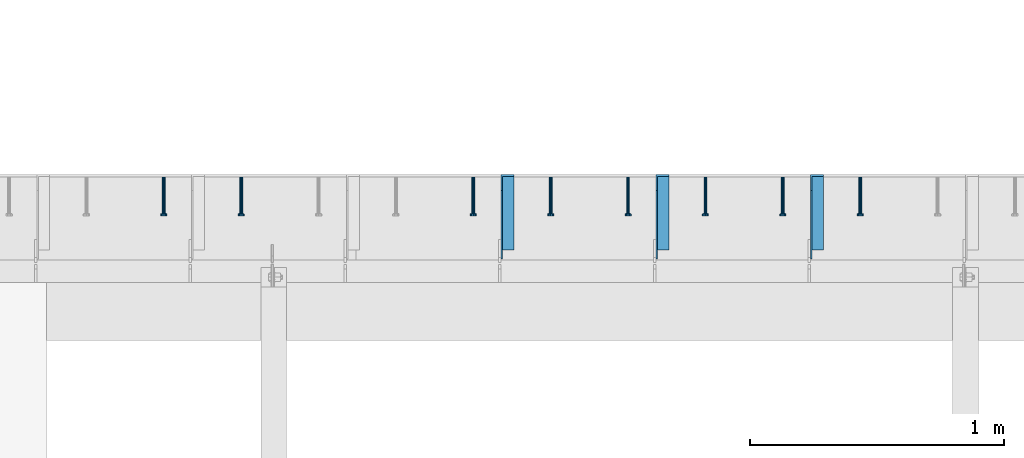
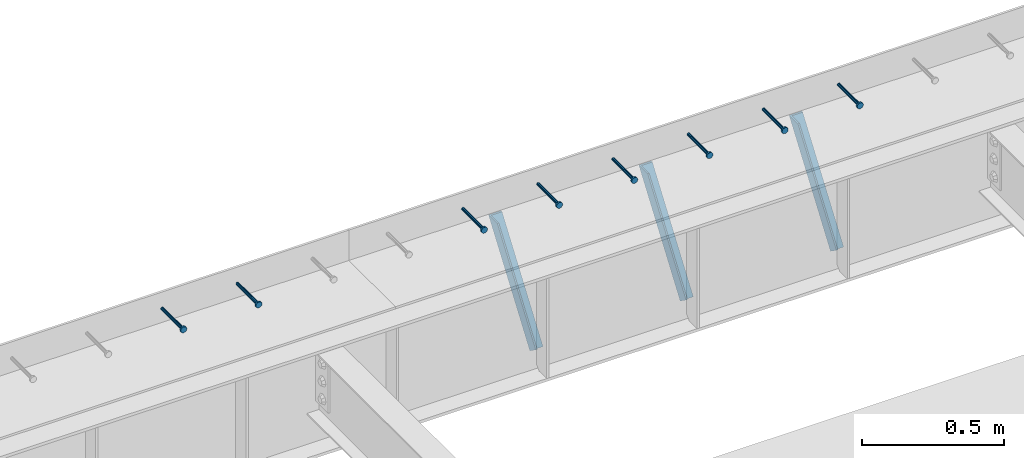
# One storey, part 1343 of 1763: 8 beams, 3 members, 9 elements without a shape of their own.
"""IFC2X3 building model written with IfcOpenShell, lengths in millimetres."""

from ifc_helpers import new_model, si_unit, frame, origin_with_axes, place, context, subcontext, project, spatial, faceted_brep, material, type_object, element, aggregate, save


model = new_model("IFC2X3")

# Units and contexts
model_context = context("Model", 3, precision=1e-05, world=origin_with_axes())
body_context = subcontext(model_context, "Body", "Model", "MODEL_VIEW")
ifc_project = project(units=[si_unit("LENGTHUNIT", "METRE", prefix="MILLI"), si_unit("AREAUNIT", "SQUARE_METRE"), si_unit("VOLUMEUNIT", "CUBIC_METRE"), si_unit("MASSUNIT", "GRAM", prefix="KILO"), si_unit("TIMEUNIT", "SECOND"), si_unit("PLANEANGLEUNIT", "RADIAN"), si_unit("SOLIDANGLEUNIT", "STERADIAN"), si_unit("THERMODYNAMICTEMPERATUREUNIT", "DEGREE_CELSIUS"), si_unit("LUMINOUSINTENSITYUNIT", "LUMEN")], contexts=[model_context])

# Site, building, storey
site_placement = place(None, origin_with_axes())
site = spatial("IfcSite", under=ifc_project, at=site_placement, CompositionType="ELEMENT")
building_placement = place(site_placement, origin_with_axes())
building = spatial("IfcBuilding", under=site, at=building_placement, Name="Undefined", CompositionType="ELEMENT")
storey_placement = place(building_placement, origin_with_axes())
storey = spatial("IfcBuildingStorey", under=building, at=storey_placement, Name="Undefined", CompositionType="ELEMENT", Elevation=0.0)

# Assembly, beam
assembly_1_placement = place(storey_placement, origin_with_axes())
assembly_1 = element("IfcElementAssembly", 1, at=assembly_1_placement, inside=storey, Name="HEADED STUD ANCHOR", AssemblyPlace="NOTDEFINED", PredefinedType="RIGID_FRAME")
ifc_material_1 = material(Name="STEEL/A108")
beam_type = type_object("IfcBeamType", PredefinedType="NOTDEFINED")
beam_1_placement = place(assembly_1_placement, frame((-67457.0747736983, 53984.5250183106, 5264.23140606069), z_axis=(0.0, 0.0, 1.0), x_axis=(0.0, -1.0, 0.0)))
beam_1 = element("IfcBeam", 2, at=beam_1_placement, type_object=beam_type, material=ifc_material_1, Name="HEADED STUD ANCHOR", context=body_context, shape_type="Brep", body=[
    faceted_brep([(0.0, -3.1800000667572, 5.5), (0.0, -5.5, 3.1800000667572), (141.732000000002, -5.5, 3.1800000667572), (141.732000000002, -3.1800000667572, 5.5), (0.0, -6.34999999999491, 1.45519152283669e-11), (141.732000000002, -6.34999990463257, 0.0), (0.0, -5.5, -3.1800000667572), (141.732000000002, -5.5, -3.1800000667572), (0.0, -3.1800000667572, -5.5), (141.732000000002, -3.1800000667572, -5.5), (0.0, 0.0, -6.34999990463257), (141.732000000002, 0.0, -6.34999990463257), (0.0, 3.1800000667572, -5.5), (141.732000000002, 3.1800000667572, -5.5), (0.0, 5.5, -3.1800000667572), (141.732000000002, 5.5, -3.1800000667572), (0.0, 6.34999999999491, -2.91038304567337e-11), (141.732000000002, 6.34999990463257, 0.0), (0.0, 5.5, 3.1800000667572), (141.732000000002, 5.5, 3.1800000667572), (0.0, 3.1800000667572, 5.5), (141.732000000002, 3.1800000667572, 5.5), (0.0, 0.0, 6.34999990463257), (141.732000000002, 0.0, 6.34999990463257), (144.780000000001, -10.9899997711182, 6.34999990463257), (144.780000000001, -6.34000015258789, 10.9899997711182), (144.780000000001, -12.6999998092651, 0.0), (144.780000000001, -10.9899997711182, -6.34999990463257), (144.780000000001, -6.34000015258789, -10.9899997711182), (144.780000000001, 0.0, -12.6899995803833), (144.780000000001, 6.34000015258789, -10.9899997711182), (144.780000000001, 10.9899997711182, -6.34999990463257), (144.780000000001, 12.6999998092651, 0.0), (144.780000000001, 10.9899997711182, 6.34999990463257), (144.780000000001, 6.34000015258789, 10.9899997711182), (144.780000000001, 0.0, 12.6899995803833), (152.400000000001, -10.9899997711182, 6.34999990463257), (152.400000000001, -6.34000015258789, 10.9899997711182), (152.400000000001, -12.6999998092651, 0.0), (152.400000000001, -10.9899997711182, -6.34999990463257), (152.400000000001, -6.34000015258789, -10.9899997711182), (152.400000000001, 0.0, -12.6899995803833), (152.400000000001, 6.34000015258789, -10.9899997711182), (152.400000000001, 10.9899997711182, -6.34999990463257), (152.400000000001, 12.6999998092651, 0.0), (152.400000000001, 10.9899997711182, 6.34999990463257), (152.400000000001, 6.34000015258789, 10.9899997711182), (152.400000000001, 0.0, 12.6899995803833)], [[[0, 1, 2, 3]], [[1, 4, 5, 2]], [[4, 6, 7, 5]], [[6, 8, 9, 7]], [[8, 10, 11, 9]], [[10, 12, 13, 11]], [[12, 14, 15, 13]], [[14, 16, 17, 15]], [[16, 18, 19, 17]], [[18, 20, 21, 19]], [[20, 22, 23, 21]], [[22, 0, 3, 23]], [[22, 20, 18, 16, 14, 12, 10, 8, 6, 4, 1, 0]], [[3, 2, 24, 25]], [[2, 5, 26, 24]], [[5, 7, 27, 26]], [[7, 9, 28, 27]], [[9, 11, 29, 28]], [[11, 13, 30, 29]], [[13, 15, 31, 30]], [[15, 17, 32, 31]], [[17, 19, 33, 32]], [[19, 21, 34, 33]], [[21, 23, 35, 34]], [[23, 3, 25, 35]], [[25, 24, 36, 37]], [[24, 26, 38, 36]], [[26, 27, 39, 38]], [[27, 28, 40, 39]], [[28, 29, 41, 40]], [[29, 30, 42, 41]], [[30, 31, 43, 42]], [[31, 32, 44, 43]], [[32, 33, 45, 44]], [[33, 34, 46, 45]], [[34, 35, 47, 46]], [[35, 25, 37, 47]], [[38, 39, 40, 41, 42, 43, 44, 45, 46, 47, 37, 36]]]),
])
aggregate(assembly_1, [beam_1])

assembly_2_placement = place(storey_placement, origin_with_axes())
assembly_2 = element("IfcElementAssembly", 3, at=assembly_2_placement, inside=storey, Name="HEADED STUD ANCHOR", AssemblyPlace="NOTDEFINED", PredefinedType="RIGID_FRAME")
beam_2_placement = place(assembly_2_placement, frame((-67761.8747736983, 53984.5250183106, 5264.23140606069), z_axis=(0.0, 0.0, 1.0), x_axis=(0.0, -1.0, 0.0)))
beam_2 = element("IfcBeam", 4, at=beam_2_placement, type_object=beam_type, material=ifc_material_1, Name="HEADED STUD ANCHOR", context=body_context, shape_type="Brep", body=[
    faceted_brep([(0.0, -3.1800000667572, 5.5), (0.0, -5.5, 3.1800000667572), (141.732000000002, -5.5, 3.1800000667572), (141.732000000002, -3.1800000667572, 5.5), (0.0, -6.34999999999491, 1.45519152283669e-11), (141.732000000002, -6.34999990463257, 0.0), (0.0, -5.5, -3.1800000667572), (141.732000000002, -5.5, -3.1800000667572), (0.0, -3.1800000667572, -5.5), (141.732000000002, -3.1800000667572, -5.5), (0.0, 0.0, -6.34999990463257), (141.732000000002, 0.0, -6.34999990463257), (0.0, 3.1800000667572, -5.5), (141.732000000002, 3.1800000667572, -5.5), (0.0, 5.5, -3.1800000667572), (141.732000000002, 5.5, -3.1800000667572), (0.0, 6.34999999999491, -2.91038304567337e-11), (141.732000000002, 6.34999990463257, 0.0), (0.0, 5.5, 3.1800000667572), (141.732000000002, 5.5, 3.1800000667572), (0.0, 3.1800000667572, 5.5), (141.732000000002, 3.1800000667572, 5.5), (0.0, 0.0, 6.34999990463257), (141.732000000002, 0.0, 6.34999990463257), (144.780000000001, -10.9899997711182, 6.34999990463257), (144.780000000001, -6.34000015258789, 10.9899997711182), (144.780000000001, -12.6999998092651, 0.0), (144.780000000001, -10.9899997711182, -6.34999990463257), (144.780000000001, -6.34000015258789, -10.9899997711182), (144.780000000001, 0.0, -12.6899995803833), (144.780000000001, 6.34000015258789, -10.9899997711182), (144.780000000001, 10.9899997711182, -6.34999990463257), (144.780000000001, 12.6999998092651, 0.0), (144.780000000001, 10.9899997711182, 6.34999990463257), (144.780000000001, 6.34000015258789, 10.9899997711182), (144.780000000001, 0.0, 12.6899995803833), (152.400000000001, -10.9899997711182, 6.34999990463257), (152.400000000001, -6.34000015258789, 10.9899997711182), (152.400000000001, -12.6999998092651, 0.0), (152.400000000001, -10.9899997711182, -6.34999990463257), (152.400000000001, -6.34000015258789, -10.9899997711182), (152.400000000001, 0.0, -12.6899995803833), (152.400000000001, 6.34000015258789, -10.9899997711182), (152.400000000001, 10.9899997711182, -6.34999990463257), (152.400000000001, 12.6999998092651, 0.0), (152.400000000001, 10.9899997711182, 6.34999990463257), (152.400000000001, 6.34000015258789, 10.9899997711182), (152.400000000001, 0.0, 12.6899995803833)], [[[0, 1, 2, 3]], [[1, 4, 5, 2]], [[4, 6, 7, 5]], [[6, 8, 9, 7]], [[8, 10, 11, 9]], [[10, 12, 13, 11]], [[12, 14, 15, 13]], [[14, 16, 17, 15]], [[16, 18, 19, 17]], [[18, 20, 21, 19]], [[20, 22, 23, 21]], [[22, 0, 3, 23]], [[22, 20, 18, 16, 14, 12, 10, 8, 6, 4, 1, 0]], [[3, 2, 24, 25]], [[2, 5, 26, 24]], [[5, 7, 27, 26]], [[7, 9, 28, 27]], [[9, 11, 29, 28]], [[11, 13, 30, 29]], [[13, 15, 31, 30]], [[15, 17, 32, 31]], [[17, 19, 33, 32]], [[19, 21, 34, 33]], [[21, 23, 35, 34]], [[23, 3, 25, 35]], [[25, 24, 36, 37]], [[24, 26, 38, 36]], [[26, 27, 39, 38]], [[27, 28, 40, 39]], [[28, 29, 41, 40]], [[29, 30, 42, 41]], [[30, 31, 43, 42]], [[31, 32, 44, 43]], [[32, 33, 45, 44]], [[33, 34, 46, 45]], [[34, 35, 47, 46]], [[35, 25, 37, 47]], [[38, 39, 40, 41, 42, 43, 44, 45, 46, 47, 37, 36]]]),
])
aggregate(assembly_2, [beam_2])

assembly_3_placement = place(storey_placement, origin_with_axes())
assembly_3 = element("IfcElementAssembly", 5, at=assembly_3_placement, inside=storey, Name="HEADED STUD ANCHOR", AssemblyPlace="NOTDEFINED", PredefinedType="RIGID_FRAME")
beam_3_placement = place(assembly_3_placement, frame((-68066.6747736984, 53984.5250183106, 5264.23140606069), z_axis=(0.0, 0.0, 1.0), x_axis=(0.0, -1.0, 0.0)))
beam_3 = element("IfcBeam", 6, at=beam_3_placement, type_object=beam_type, material=ifc_material_1, Name="HEADED STUD ANCHOR", context=body_context, shape_type="Brep", body=[
    faceted_brep([(0.0, -3.1800000667572, 5.5), (0.0, -5.5, 3.1800000667572), (141.732000000002, -5.5, 3.1800000667572), (141.732000000002, -3.1800000667572, 5.5), (0.0, -6.34999999999491, 1.45519152283669e-11), (141.732000000002, -6.34999990463257, 0.0), (0.0, -5.5, -3.1800000667572), (141.732000000002, -5.5, -3.1800000667572), (0.0, -3.1800000667572, -5.5), (141.732000000002, -3.1800000667572, -5.5), (0.0, 0.0, -6.34999990463257), (141.732000000002, 0.0, -6.34999990463257), (0.0, 3.1800000667572, -5.5), (141.732000000002, 3.1800000667572, -5.5), (0.0, 5.5, -3.1800000667572), (141.732000000002, 5.5, -3.1800000667572), (0.0, 6.34999999999491, -2.91038304567337e-11), (141.732000000002, 6.34999990463257, 0.0), (0.0, 5.5, 3.1800000667572), (141.732000000002, 5.5, 3.1800000667572), (0.0, 3.1800000667572, 5.5), (141.732000000002, 3.1800000667572, 5.5), (0.0, 0.0, 6.34999990463257), (141.732000000002, 0.0, 6.34999990463257), (144.780000000001, -10.9899997711182, 6.34999990463257), (144.780000000001, -6.34000015258789, 10.9899997711182), (144.780000000001, -12.6999998092651, 0.0), (144.780000000001, -10.9899997711182, -6.34999990463257), (144.780000000001, -6.34000015258789, -10.9899997711182), (144.780000000001, 0.0, -12.6899995803833), (144.780000000001, 6.34000015258789, -10.9899997711182), (144.780000000001, 10.9899997711182, -6.34999990463257), (144.780000000001, 12.6999998092651, 0.0), (144.780000000001, 10.9899997711182, 6.34999990463257), (144.780000000001, 6.34000015258789, 10.9899997711182), (144.780000000001, 0.0, 12.6899995803833), (152.400000000001, -10.9899997711182, 6.34999990463257), (152.400000000001, -6.34000015258789, 10.9899997711182), (152.400000000001, -12.6999998092651, 0.0), (152.400000000001, -10.9899997711182, -6.34999990463257), (152.400000000001, -6.34000015258789, -10.9899997711182), (152.400000000001, 0.0, -12.6899995803833), (152.400000000001, 6.34000015258789, -10.9899997711182), (152.400000000001, 10.9899997711182, -6.34999990463257), (152.400000000001, 12.6999998092651, 0.0), (152.400000000001, 10.9899997711182, 6.34999990463257), (152.400000000001, 6.34000015258789, 10.9899997711182), (152.400000000001, 0.0, 12.6899995803833)], [[[0, 1, 2, 3]], [[1, 4, 5, 2]], [[4, 6, 7, 5]], [[6, 8, 9, 7]], [[8, 10, 11, 9]], [[10, 12, 13, 11]], [[12, 14, 15, 13]], [[14, 16, 17, 15]], [[16, 18, 19, 17]], [[18, 20, 21, 19]], [[20, 22, 23, 21]], [[22, 0, 3, 23]], [[22, 20, 18, 16, 14, 12, 10, 8, 6, 4, 1, 0]], [[3, 2, 24, 25]], [[2, 5, 26, 24]], [[5, 7, 27, 26]], [[7, 9, 28, 27]], [[9, 11, 29, 28]], [[11, 13, 30, 29]], [[13, 15, 31, 30]], [[15, 17, 32, 31]], [[17, 19, 33, 32]], [[19, 21, 34, 33]], [[21, 23, 35, 34]], [[23, 3, 25, 35]], [[25, 24, 36, 37]], [[24, 26, 38, 36]], [[26, 27, 39, 38]], [[27, 28, 40, 39]], [[28, 29, 41, 40]], [[29, 30, 42, 41]], [[30, 31, 43, 42]], [[31, 32, 44, 43]], [[32, 33, 45, 44]], [[33, 34, 46, 45]], [[34, 35, 47, 46]], [[35, 25, 37, 47]], [[38, 39, 40, 41, 42, 43, 44, 45, 46, 47, 37, 36]]]),
])
aggregate(assembly_3, [beam_3])

assembly_4_placement = place(storey_placement, origin_with_axes())
assembly_4 = element("IfcElementAssembly", 7, at=assembly_4_placement, inside=storey, Name="HEADED STUD ANCHOR", AssemblyPlace="NOTDEFINED", PredefinedType="RIGID_FRAME")
beam_4_placement = place(assembly_4_placement, frame((-68371.4747736984, 53984.5250183106, 5264.23140606069), z_axis=(0.0, 0.0, 1.0), x_axis=(0.0, -1.0, 0.0)))
beam_4 = element("IfcBeam", 8, at=beam_4_placement, type_object=beam_type, material=ifc_material_1, Name="HEADED STUD ANCHOR", context=body_context, shape_type="Brep", body=[
    faceted_brep([(0.0, -3.1800000667572, 5.5), (0.0, -5.5, 3.1800000667572), (141.732000000002, -5.5, 3.1800000667572), (141.732000000002, -3.1800000667572, 5.5), (0.0, -6.34999999999491, 1.45519152283669e-11), (141.732000000002, -6.34999990463257, 0.0), (0.0, -5.5, -3.1800000667572), (141.732000000002, -5.5, -3.1800000667572), (0.0, -3.1800000667572, -5.5), (141.732000000002, -3.1800000667572, -5.5), (0.0, 0.0, -6.34999990463257), (141.732000000002, 0.0, -6.34999990463257), (0.0, 3.1800000667572, -5.5), (141.732000000002, 3.1800000667572, -5.5), (0.0, 5.5, -3.1800000667572), (141.732000000002, 5.5, -3.1800000667572), (0.0, 6.34999999999491, -2.91038304567337e-11), (141.732000000002, 6.34999990463257, 0.0), (0.0, 5.5, 3.1800000667572), (141.732000000002, 5.5, 3.1800000667572), (0.0, 3.1800000667572, 5.5), (141.732000000002, 3.1800000667572, 5.5), (0.0, 0.0, 6.34999990463257), (141.732000000002, 0.0, 6.34999990463257), (144.780000000001, -10.9899997711182, 6.34999990463257), (144.780000000001, -6.34000015258789, 10.9899997711182), (144.780000000001, -12.6999998092651, 0.0), (144.780000000001, -10.9899997711182, -6.34999990463257), (144.780000000001, -6.34000015258789, -10.9899997711182), (144.780000000001, 0.0, -12.6899995803833), (144.780000000001, 6.34000015258789, -10.9899997711182), (144.780000000001, 10.9899997711182, -6.34999990463257), (144.780000000001, 12.6999998092651, 0.0), (144.780000000001, 10.9899997711182, 6.34999990463257), (144.780000000001, 6.34000015258789, 10.9899997711182), (144.780000000001, 0.0, 12.6899995803833), (152.400000000001, -10.9899997711182, 6.34999990463257), (152.400000000001, -6.34000015258789, 10.9899997711182), (152.400000000001, -12.6999998092651, 0.0), (152.400000000001, -10.9899997711182, -6.34999990463257), (152.400000000001, -6.34000015258789, -10.9899997711182), (152.400000000001, 0.0, -12.6899995803833), (152.400000000001, 6.34000015258789, -10.9899997711182), (152.400000000001, 10.9899997711182, -6.34999990463257), (152.400000000001, 12.6999998092651, 0.0), (152.400000000001, 10.9899997711182, 6.34999990463257), (152.400000000001, 6.34000015258789, 10.9899997711182), (152.400000000001, 0.0, 12.6899995803833)], [[[0, 1, 2, 3]], [[1, 4, 5, 2]], [[4, 6, 7, 5]], [[6, 8, 9, 7]], [[8, 10, 11, 9]], [[10, 12, 13, 11]], [[12, 14, 15, 13]], [[14, 16, 17, 15]], [[16, 18, 19, 17]], [[18, 20, 21, 19]], [[20, 22, 23, 21]], [[22, 0, 3, 23]], [[22, 20, 18, 16, 14, 12, 10, 8, 6, 4, 1, 0]], [[3, 2, 24, 25]], [[2, 5, 26, 24]], [[5, 7, 27, 26]], [[7, 9, 28, 27]], [[9, 11, 29, 28]], [[11, 13, 30, 29]], [[13, 15, 31, 30]], [[15, 17, 32, 31]], [[17, 19, 33, 32]], [[19, 21, 34, 33]], [[21, 23, 35, 34]], [[23, 3, 25, 35]], [[25, 24, 36, 37]], [[24, 26, 38, 36]], [[26, 27, 39, 38]], [[27, 28, 40, 39]], [[28, 29, 41, 40]], [[29, 30, 42, 41]], [[30, 31, 43, 42]], [[31, 32, 44, 43]], [[32, 33, 45, 44]], [[33, 34, 46, 45]], [[34, 35, 47, 46]], [[35, 25, 37, 47]], [[38, 39, 40, 41, 42, 43, 44, 45, 46, 47, 37, 36]]]),
])
aggregate(assembly_4, [beam_4])

assembly_5_placement = place(storey_placement, origin_with_axes())
assembly_5 = element("IfcElementAssembly", 9, at=assembly_5_placement, inside=storey, Name="HEADED STUD ANCHOR", AssemblyPlace="NOTDEFINED", PredefinedType="RIGID_FRAME")
beam_5_placement = place(assembly_5_placement, frame((-68676.2747736983, 53984.5250183106, 5264.23140606069), z_axis=(0.0, 0.0, 1.0), x_axis=(0.0, -1.0, 0.0)))
beam_5 = element("IfcBeam", 10, at=beam_5_placement, type_object=beam_type, material=ifc_material_1, Name="HEADED STUD ANCHOR", context=body_context, shape_type="Brep", body=[
    faceted_brep([(0.0, -3.1800000667572, 5.5), (0.0, -5.5, 3.1800000667572), (141.732000000002, -5.5, 3.1800000667572), (141.732000000002, -3.1800000667572, 5.5), (0.0, -6.34999999999491, 1.45519152283669e-11), (141.732000000002, -6.34999990463257, 0.0), (0.0, -5.5, -3.1800000667572), (141.732000000002, -5.5, -3.1800000667572), (0.0, -3.1800000667572, -5.5), (141.732000000002, -3.1800000667572, -5.5), (0.0, 0.0, -6.34999990463257), (141.732000000002, 0.0, -6.34999990463257), (0.0, 3.1800000667572, -5.5), (141.732000000002, 3.1800000667572, -5.5), (0.0, 5.5, -3.1800000667572), (141.732000000002, 5.5, -3.1800000667572), (0.0, 6.34999999999491, -2.91038304567337e-11), (141.732000000002, 6.34999990463257, 0.0), (0.0, 5.5, 3.1800000667572), (141.732000000002, 5.5, 3.1800000667572), (0.0, 3.1800000667572, 5.5), (141.732000000002, 3.1800000667572, 5.5), (0.0, 0.0, 6.34999990463257), (141.732000000002, 0.0, 6.34999990463257), (144.780000000001, -10.9899997711182, 6.34999990463257), (144.780000000001, -6.34000015258789, 10.9899997711182), (144.780000000001, -12.6999998092651, 0.0), (144.780000000001, -10.9899997711182, -6.34999990463257), (144.780000000001, -6.34000015258789, -10.9899997711182), (144.780000000001, 0.0, -12.6899995803833), (144.780000000001, 6.34000015258789, -10.9899997711182), (144.780000000001, 10.9899997711182, -6.34999990463257), (144.780000000001, 12.6999998092651, 0.0), (144.780000000001, 10.9899997711182, 6.34999990463257), (144.780000000001, 6.34000015258789, 10.9899997711182), (144.780000000001, 0.0, 12.6899995803833), (152.400000000001, -10.9899997711182, 6.34999990463257), (152.400000000001, -6.34000015258789, 10.9899997711182), (152.400000000001, -12.6999998092651, 0.0), (152.400000000001, -10.9899997711182, -6.34999990463257), (152.400000000001, -6.34000015258789, -10.9899997711182), (152.400000000001, 0.0, -12.6899995803833), (152.400000000001, 6.34000015258789, -10.9899997711182), (152.400000000001, 10.9899997711182, -6.34999990463257), (152.400000000001, 12.6999998092651, 0.0), (152.400000000001, 10.9899997711182, 6.34999990463257), (152.400000000001, 6.34000015258789, 10.9899997711182), (152.400000000001, 0.0, 12.6899995803833)], [[[0, 1, 2, 3]], [[1, 4, 5, 2]], [[4, 6, 7, 5]], [[6, 8, 9, 7]], [[8, 10, 11, 9]], [[10, 12, 13, 11]], [[12, 14, 15, 13]], [[14, 16, 17, 15]], [[16, 18, 19, 17]], [[18, 20, 21, 19]], [[20, 22, 23, 21]], [[22, 0, 3, 23]], [[22, 20, 18, 16, 14, 12, 10, 8, 6, 4, 1, 0]], [[3, 2, 24, 25]], [[2, 5, 26, 24]], [[5, 7, 27, 26]], [[7, 9, 28, 27]], [[9, 11, 29, 28]], [[11, 13, 30, 29]], [[13, 15, 31, 30]], [[15, 17, 32, 31]], [[17, 19, 33, 32]], [[19, 21, 34, 33]], [[21, 23, 35, 34]], [[23, 3, 25, 35]], [[25, 24, 36, 37]], [[24, 26, 38, 36]], [[26, 27, 39, 38]], [[27, 28, 40, 39]], [[28, 29, 41, 40]], [[29, 30, 42, 41]], [[30, 31, 43, 42]], [[31, 32, 44, 43]], [[32, 33, 45, 44]], [[33, 34, 46, 45]], [[34, 35, 47, 46]], [[35, 25, 37, 47]], [[38, 39, 40, 41, 42, 43, 44, 45, 46, 47, 37, 36]]]),
])
aggregate(assembly_5, [beam_5])

assembly_6_placement = place(storey_placement, origin_with_axes())
assembly_6 = element("IfcElementAssembly", 11, at=assembly_6_placement, inside=storey, Name="HEADED STUD ANCHOR", AssemblyPlace="NOTDEFINED", PredefinedType="RIGID_FRAME")
beam_6_placement = place(assembly_6_placement, frame((-68981.0747736983, 53984.5250183106, 5264.23140606069), z_axis=(0.0, 0.0, 1.0), x_axis=(0.0, -1.0, 0.0)))
beam_6 = element("IfcBeam", 12, at=beam_6_placement, type_object=beam_type, material=ifc_material_1, Name="HEADED STUD ANCHOR", context=body_context, shape_type="Brep", body=[
    faceted_brep([(0.0, -3.1800000667572, 5.5), (0.0, -5.5, 3.1800000667572), (141.732000000002, -5.5, 3.1800000667572), (141.732000000002, -3.1800000667572, 5.5), (0.0, -6.34999999999491, 1.45519152283669e-11), (141.732000000002, -6.34999990463257, 0.0), (0.0, -5.5, -3.1800000667572), (141.732000000002, -5.5, -3.1800000667572), (0.0, -3.1800000667572, -5.5), (141.732000000002, -3.1800000667572, -5.5), (0.0, 0.0, -6.34999990463257), (141.732000000002, 0.0, -6.34999990463257), (0.0, 3.1800000667572, -5.5), (141.732000000002, 3.1800000667572, -5.5), (0.0, 5.5, -3.1800000667572), (141.732000000002, 5.5, -3.1800000667572), (0.0, 6.34999999999491, -2.91038304567337e-11), (141.732000000002, 6.34999990463257, 0.0), (0.0, 5.5, 3.1800000667572), (141.732000000002, 5.5, 3.1800000667572), (0.0, 3.1800000667572, 5.5), (141.732000000002, 3.1800000667572, 5.5), (0.0, 0.0, 6.34999990463257), (141.732000000002, 0.0, 6.34999990463257), (144.780000000001, -10.9899997711182, 6.34999990463257), (144.780000000001, -6.34000015258789, 10.9899997711182), (144.780000000001, -12.6999998092651, 0.0), (144.780000000001, -10.9899997711182, -6.34999990463257), (144.780000000001, -6.34000015258789, -10.9899997711182), (144.780000000001, 0.0, -12.6899995803833), (144.780000000001, 6.34000015258789, -10.9899997711182), (144.780000000001, 10.9899997711182, -6.34999990463257), (144.780000000001, 12.6999998092651, 0.0), (144.780000000001, 10.9899997711182, 6.34999990463257), (144.780000000001, 6.34000015258789, 10.9899997711182), (144.780000000001, 0.0, 12.6899995803833), (152.400000000001, -10.9899997711182, 6.34999990463257), (152.400000000001, -6.34000015258789, 10.9899997711182), (152.400000000001, -12.6999998092651, 0.0), (152.400000000001, -10.9899997711182, -6.34999990463257), (152.400000000001, -6.34000015258789, -10.9899997711182), (152.400000000001, 0.0, -12.6899995803833), (152.400000000001, 6.34000015258789, -10.9899997711182), (152.400000000001, 10.9899997711182, -6.34999990463257), (152.400000000001, 12.6999998092651, 0.0), (152.400000000001, 10.9899997711182, 6.34999990463257), (152.400000000001, 6.34000015258789, 10.9899997711182), (152.400000000001, 0.0, 12.6899995803833)], [[[0, 1, 2, 3]], [[1, 4, 5, 2]], [[4, 6, 7, 5]], [[6, 8, 9, 7]], [[8, 10, 11, 9]], [[10, 12, 13, 11]], [[12, 14, 15, 13]], [[14, 16, 17, 15]], [[16, 18, 19, 17]], [[18, 20, 21, 19]], [[20, 22, 23, 21]], [[22, 0, 3, 23]], [[22, 20, 18, 16, 14, 12, 10, 8, 6, 4, 1, 0]], [[3, 2, 24, 25]], [[2, 5, 26, 24]], [[5, 7, 27, 26]], [[7, 9, 28, 27]], [[9, 11, 29, 28]], [[11, 13, 30, 29]], [[13, 15, 31, 30]], [[15, 17, 32, 31]], [[17, 19, 33, 32]], [[19, 21, 34, 33]], [[21, 23, 35, 34]], [[23, 3, 25, 35]], [[25, 24, 36, 37]], [[24, 26, 38, 36]], [[26, 27, 39, 38]], [[27, 28, 40, 39]], [[28, 29, 41, 40]], [[29, 30, 42, 41]], [[30, 31, 43, 42]], [[31, 32, 44, 43]], [[32, 33, 45, 44]], [[33, 34, 46, 45]], [[34, 35, 47, 46]], [[35, 25, 37, 47]], [[38, 39, 40, 41, 42, 43, 44, 45, 46, 47, 37, 36]]]),
])
aggregate(assembly_6, [beam_6])

assembly_7_placement = place(storey_placement, origin_with_axes())
assembly_7 = element("IfcElementAssembly", 13, at=assembly_7_placement, inside=storey, Name="HEADED STUD ANCHOR", AssemblyPlace="NOTDEFINED", PredefinedType="RIGID_FRAME")
beam_7_placement = place(assembly_7_placement, frame((-69895.4747736984, 53984.5250183106, 5264.23140606069), z_axis=(0.0, 0.0, 1.0), x_axis=(0.0, -1.0, 0.0)))
beam_7 = element("IfcBeam", 14, at=beam_7_placement, type_object=beam_type, material=ifc_material_1, Name="HEADED STUD ANCHOR", context=body_context, shape_type="Brep", body=[
    faceted_brep([(0.0, -3.1800000667572, 5.5), (0.0, -5.5, 3.1800000667572), (141.732000000002, -5.5, 3.1800000667572), (141.732000000002, -3.1800000667572, 5.5), (0.0, -6.34999999999491, 1.45519152283669e-11), (141.732000000002, -6.34999990463257, 0.0), (0.0, -5.5, -3.1800000667572), (141.732000000002, -5.5, -3.1800000667572), (0.0, -3.1800000667572, -5.5), (141.732000000002, -3.1800000667572, -5.5), (0.0, 0.0, -6.34999990463257), (141.732000000002, 0.0, -6.34999990463257), (0.0, 3.1800000667572, -5.5), (141.732000000002, 3.1800000667572, -5.5), (0.0, 5.5, -3.1800000667572), (141.732000000002, 5.5, -3.1800000667572), (0.0, 6.34999999999491, -2.91038304567337e-11), (141.732000000002, 6.34999990463257, 0.0), (0.0, 5.5, 3.1800000667572), (141.732000000002, 5.5, 3.1800000667572), (0.0, 3.1800000667572, 5.5), (141.732000000002, 3.1800000667572, 5.5), (0.0, 0.0, 6.34999990463257), (141.732000000002, 0.0, 6.34999990463257), (144.780000000001, -10.9899997711182, 6.34999990463257), (144.780000000001, -6.34000015258789, 10.9899997711182), (144.780000000001, -12.6999998092651, 0.0), (144.780000000001, -10.9899997711182, -6.34999990463257), (144.780000000001, -6.34000015258789, -10.9899997711182), (144.780000000001, 0.0, -12.6899995803833), (144.780000000001, 6.34000015258789, -10.9899997711182), (144.780000000001, 10.9899997711182, -6.34999990463257), (144.780000000001, 12.6999998092651, 0.0), (144.780000000001, 10.9899997711182, 6.34999990463257), (144.780000000001, 6.34000015258789, 10.9899997711182), (144.780000000001, 0.0, 12.6899995803833), (152.400000000001, -10.9899997711182, 6.34999990463257), (152.400000000001, -6.34000015258789, 10.9899997711182), (152.400000000001, -12.6999998092651, 0.0), (152.400000000001, -10.9899997711182, -6.34999990463257), (152.400000000001, -6.34000015258789, -10.9899997711182), (152.400000000001, 0.0, -12.6899995803833), (152.400000000001, 6.34000015258789, -10.9899997711182), (152.400000000001, 10.9899997711182, -6.34999990463257), (152.400000000001, 12.6999998092651, 0.0), (152.400000000001, 10.9899997711182, 6.34999990463257), (152.400000000001, 6.34000015258789, 10.9899997711182), (152.400000000001, 0.0, 12.6899995803833)], [[[0, 1, 2, 3]], [[1, 4, 5, 2]], [[4, 6, 7, 5]], [[6, 8, 9, 7]], [[8, 10, 11, 9]], [[10, 12, 13, 11]], [[12, 14, 15, 13]], [[14, 16, 17, 15]], [[16, 18, 19, 17]], [[18, 20, 21, 19]], [[20, 22, 23, 21]], [[22, 0, 3, 23]], [[22, 20, 18, 16, 14, 12, 10, 8, 6, 4, 1, 0]], [[3, 2, 24, 25]], [[2, 5, 26, 24]], [[5, 7, 27, 26]], [[7, 9, 28, 27]], [[9, 11, 29, 28]], [[11, 13, 30, 29]], [[13, 15, 31, 30]], [[15, 17, 32, 31]], [[17, 19, 33, 32]], [[19, 21, 34, 33]], [[21, 23, 35, 34]], [[23, 3, 25, 35]], [[25, 24, 36, 37]], [[24, 26, 38, 36]], [[26, 27, 39, 38]], [[27, 28, 40, 39]], [[28, 29, 41, 40]], [[29, 30, 42, 41]], [[30, 31, 43, 42]], [[31, 32, 44, 43]], [[32, 33, 45, 44]], [[33, 34, 46, 45]], [[34, 35, 47, 46]], [[35, 25, 37, 47]], [[38, 39, 40, 41, 42, 43, 44, 45, 46, 47, 37, 36]]]),
])
aggregate(assembly_7, [beam_7])

assembly_8_placement = place(storey_placement, origin_with_axes())
assembly_8 = element("IfcElementAssembly", 15, at=assembly_8_placement, inside=storey, Name="HEADED STUD ANCHOR", AssemblyPlace="NOTDEFINED", PredefinedType="RIGID_FRAME")
beam_8_placement = place(assembly_8_placement, frame((-70200.2747736983, 53984.5250183106, 5264.23140606069), z_axis=(0.0, 0.0, 1.0), x_axis=(0.0, -1.0, 0.0)))
beam_8 = element("IfcBeam", 16, at=beam_8_placement, type_object=beam_type, material=ifc_material_1, Name="HEADED STUD ANCHOR", context=body_context, shape_type="Brep", body=[
    faceted_brep([(0.0, -3.1800000667572, 5.5), (0.0, -5.5, 3.1800000667572), (141.732000000002, -5.5, 3.1800000667572), (141.732000000002, -3.1800000667572, 5.5), (0.0, -6.34999999999491, 1.45519152283669e-11), (141.732000000002, -6.34999990463257, 0.0), (0.0, -5.5, -3.1800000667572), (141.732000000002, -5.5, -3.1800000667572), (0.0, -3.1800000667572, -5.5), (141.732000000002, -3.1800000667572, -5.5), (0.0, 0.0, -6.34999990463257), (141.732000000002, 0.0, -6.34999990463257), (0.0, 3.1800000667572, -5.5), (141.732000000002, 3.1800000667572, -5.5), (0.0, 5.5, -3.1800000667572), (141.732000000002, 5.5, -3.1800000667572), (0.0, 6.34999999999491, -2.91038304567337e-11), (141.732000000002, 6.34999990463257, 0.0), (0.0, 5.5, 3.1800000667572), (141.732000000002, 5.5, 3.1800000667572), (0.0, 3.1800000667572, 5.5), (141.732000000002, 3.1800000667572, 5.5), (0.0, 0.0, 6.34999990463257), (141.732000000002, 0.0, 6.34999990463257), (144.780000000001, -10.9899997711182, 6.34999990463257), (144.780000000001, -6.34000015258789, 10.9899997711182), (144.780000000001, -12.6999998092651, 0.0), (144.780000000001, -10.9899997711182, -6.34999990463257), (144.780000000001, -6.34000015258789, -10.9899997711182), (144.780000000001, 0.0, -12.6899995803833), (144.780000000001, 6.34000015258789, -10.9899997711182), (144.780000000001, 10.9899997711182, -6.34999990463257), (144.780000000001, 12.6999998092651, 0.0), (144.780000000001, 10.9899997711182, 6.34999990463257), (144.780000000001, 6.34000015258789, 10.9899997711182), (144.780000000001, 0.0, 12.6899995803833), (152.400000000001, -10.9899997711182, 6.34999990463257), (152.400000000001, -6.34000015258789, 10.9899997711182), (152.400000000001, -12.6999998092651, 0.0), (152.400000000001, -10.9899997711182, -6.34999990463257), (152.400000000001, -6.34000015258789, -10.9899997711182), (152.400000000001, 0.0, -12.6899995803833), (152.400000000001, 6.34000015258789, -10.9899997711182), (152.400000000001, 10.9899997711182, -6.34999990463257), (152.400000000001, 12.6999998092651, 0.0), (152.400000000001, 10.9899997711182, 6.34999990463257), (152.400000000001, 6.34000015258789, 10.9899997711182), (152.400000000001, 0.0, 12.6899995803833)], [[[0, 1, 2, 3]], [[1, 4, 5, 2]], [[4, 6, 7, 5]], [[6, 8, 9, 7]], [[8, 10, 11, 9]], [[10, 12, 13, 11]], [[12, 14, 15, 13]], [[14, 16, 17, 15]], [[16, 18, 19, 17]], [[18, 20, 21, 19]], [[20, 22, 23, 21]], [[22, 0, 3, 23]], [[22, 20, 18, 16, 14, 12, 10, 8, 6, 4, 1, 0]], [[3, 2, 24, 25]], [[2, 5, 26, 24]], [[5, 7, 27, 26]], [[7, 9, 28, 27]], [[9, 11, 29, 28]], [[11, 13, 30, 29]], [[13, 15, 31, 30]], [[15, 17, 32, 31]], [[17, 19, 33, 32]], [[19, 21, 34, 33]], [[21, 23, 35, 34]], [[23, 3, 25, 35]], [[25, 24, 36, 37]], [[24, 26, 38, 36]], [[26, 27, 39, 38]], [[27, 28, 40, 39]], [[28, 29, 41, 40]], [[29, 30, 42, 41]], [[30, 31, 43, 42]], [[31, 32, 44, 43]], [[32, 33, 45, 44]], [[33, 34, 46, 45]], [[34, 35, 47, 46]], [[35, 25, 37, 47]], [[38, 39, 40, 41, 42, 43, 44, 45, 46, 47, 37, 36]]]),
])
aggregate(assembly_8, [beam_8])

# Assembly, members
assembly_9_placement = place(storey_placement, origin_with_axes())
assembly_9 = element("IfcElementAssembly", 17, at=assembly_9_placement, inside=storey, Name="BEAM", AssemblyPlace="NOTDEFINED", PredefinedType="RIGID_FRAME")
ifc_material_2 = material(Name="STEEL/A36")
member_type = type_object("IfcMemberType", Name="L2X2X1/4", PredefinedType="NOTDEFINED")
member_1_placement = place(assembly_9_placement, frame((-67626.9372736984, 53682.7083833994, 4801.55161052493), z_axis=(0.0, -0.814117947745209, 0.580699549818259), x_axis=(0.0, 0.58069954981826, 0.814117947745209)))
member_1 = element("IfcMember", 18, at=member_1_placement, type_object=member_type, material=ifc_material_2, Name="ANGLE", ObjectType="L2X2X1/4", context=body_context, shape_type="Brep", body=[
    faceted_brep([(-1.45519152283669e-11, 25.4000000000015, -25.3999999999869), (1.45519152283669e-11, 25.4000000000015, 25.3999999999796), (464.304493432646, 25.4000000000015, 25.3999999991429), (500.539460322936, 25.4000000000015, -25.4000000009546), (1.45519152283669e-11, 19.0499999999993, 25.3999999999796), (464.304493432646, 19.0500000000029, 25.3999999991429), (-7.27595761418343e-12, 19.0499999999993, -19.0499999999956), (496.010089461648, 19.0500000000029, -19.0500000009415), (-7.27595761418343e-12, -25.4000000000015, -19.0499999999956), (496.010089461648, -25.4000000000015, -19.0500000009415), (-1.45519152283669e-11, -25.4000000000015, -25.3999999999869), (500.539460322936, -25.4000000000015, -25.4000000009546)], [[[0, 1, 2, 3]], [[1, 4, 5, 2]], [[4, 6, 7, 5]], [[6, 8, 9, 7]], [[8, 10, 11, 9]], [[10, 0, 3, 11]], [[5, 7, 9, 11, 3, 2]], [[10, 8, 6, 4, 1, 0]]]),
])
member_2_placement = place(assembly_9_placement, frame((-68846.1372736984, 53682.7083833993, 4801.55161052492), z_axis=(0.0, -0.814117947745209, 0.580699549818259), x_axis=(0.0, 0.58069954981826, 0.814117947745209)))
member_2 = element("IfcMember", 19, at=member_2_placement, type_object=member_type, material=ifc_material_2, Name="ANGLE", ObjectType="L2X2X1/4", context=body_context, shape_type="Brep", body=[
    faceted_brep([(-1.45519152283669e-11, 25.4000000000015, -25.3999999999869), (1.45519152283669e-11, 25.4000000000015, 25.3999999999796), (464.304493432646, 25.4000000000015, 25.3999999991429), (500.539460322936, 25.4000000000015, -25.4000000009546), (1.45519152283669e-11, 19.0499999999993, 25.3999999999796), (464.304493432646, 19.0500000000029, 25.3999999991429), (-7.27595761418343e-12, 19.0499999999993, -19.0499999999956), (496.010089461648, 19.0500000000029, -19.0500000009415), (-7.27595761418343e-12, -25.4000000000015, -19.0499999999956), (496.010089461648, -25.4000000000015, -19.0500000009415), (-1.45519152283669e-11, -25.4000000000015, -25.3999999999869), (500.539460322936, -25.4000000000015, -25.4000000009546)], [[[0, 1, 2, 3]], [[1, 4, 5, 2]], [[4, 6, 7, 5]], [[6, 8, 9, 7]], [[8, 10, 11, 9]], [[10, 0, 3, 11]], [[5, 7, 9, 11, 3, 2]], [[10, 8, 6, 4, 1, 0]]]),
])
member_3_placement = place(assembly_9_placement, frame((-68236.5372736984, 53682.7083833994, 4801.55161052493), z_axis=(0.0, -0.814117947745209, 0.580699549818259), x_axis=(0.0, 0.58069954981826, 0.814117947745209)))
member_3 = element("IfcMember", 20, at=member_3_placement, type_object=member_type, material=ifc_material_2, Name="ANGLE", ObjectType="L2X2X1/4", context=body_context, shape_type="Brep", body=[
    faceted_brep([(-1.45519152283669e-11, 25.4000000000015, -25.3999999999869), (1.45519152283669e-11, 25.4000000000015, 25.3999999999796), (464.304493432646, 25.4000000000015, 25.3999999991429), (500.539460322936, 25.4000000000015, -25.4000000009546), (1.45519152283669e-11, 19.0499999999993, 25.3999999999796), (464.304493432646, 19.0500000000029, 25.3999999991429), (-7.27595761418343e-12, 19.0499999999993, -19.0499999999956), (496.010089461648, 19.0500000000029, -19.0500000009415), (-7.27595761418343e-12, -25.4000000000015, -19.0499999999956), (496.010089461648, -25.4000000000015, -19.0500000009415), (-1.45519152283669e-11, -25.4000000000015, -25.3999999999869), (500.539460322936, -25.4000000000015, -25.4000000009546)], [[[0, 1, 2, 3]], [[1, 4, 5, 2]], [[4, 6, 7, 5]], [[6, 8, 9, 7]], [[8, 10, 11, 9]], [[10, 0, 3, 11]], [[5, 7, 9, 11, 3, 2]], [[10, 8, 6, 4, 1, 0]]]),
])
aggregate(assembly_9, [member_1, member_2, member_3])

save(model, "model.ifc")
